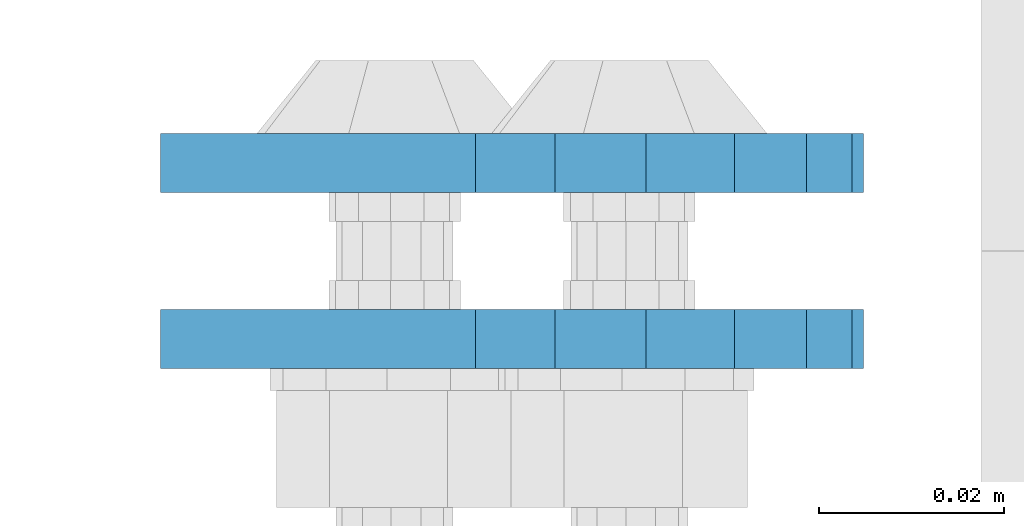
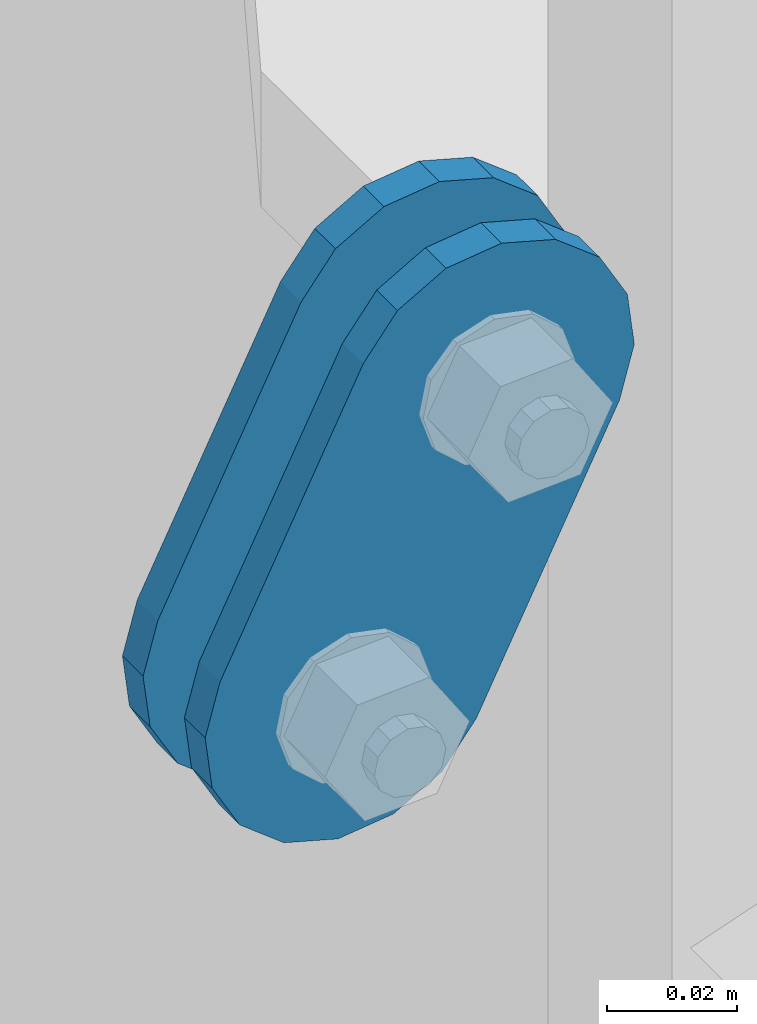
# One storey, part 1545 of 1876: 2 plates, 2 elements without a shape of their own.
"""IFC2X3 building model written with IfcOpenShell, lengths in millimetres."""

import ifcopenshell
import ifcopenshell.guid

model = None  # the IFC model being written
_history = None  # IfcOwnerHistory: only IFC2X3 demands one
_inside = {}  # id of a spatial element -> (the spatial element, [elements in it])
_under = {}  # id of a project, library or spatial element -> (it, [spatial elements below it])
_declared = {}  # id of a project -> (the project, [libraries it declares])
_typed = {}  # id of a type object -> (the type object, [elements of that type])
_made_of = {}  # id of a material, layer set ... -> (it, [elements and type objects made of it])


def new_model(schema):
    """Start an empty IFC model of exactly this schema.

    Asked for "IFC4X3", IfcOpenShell would pick the latest addendum, in which some entities
    have other attributes; the version numbers below select the first issue.
    IFC2X3 requires an IfcOwnerHistory on every rooted entity: one is made here for all.
    """
    global model, _history
    if schema == "IFC4X3":
        model = ifcopenshell.file(schema_version=(4, 3, 0, 0))
    else:
        model = ifcopenshell.file(schema=schema)
    _inside.clear()
    _under.clear()
    _declared.clear()
    _typed.clear()
    _made_of.clear()
    _history = None
    if model.schema == "IFC2X3":
        org = make("IfcOrganization", Name="unknown")
        user = make(
            "IfcPersonAndOrganization",
            ThePerson=make("IfcPerson", FamilyName="unknown"),
            TheOrganization=org,
        )
        app = make(
            "IfcApplication",
            ApplicationDeveloper=org,
            Version="unknown",
            ApplicationFullName="unknown",
            ApplicationIdentifier="unknown",
        )
        _history = make(
            "IfcOwnerHistory",
            OwningUser=user,
            OwningApplication=app,
            ChangeAction="ADDED",
            CreationDate=0,
        )
    return model


def make(cls, **values):
    """One entity of the class cls with the attributes given. An attribute that is None is left unset."""
    return model.create_entity(
        cls, **{name: value for name, value in values.items() if value is not None}
    )


def rooted(cls, **values):
    """An entity with a GlobalId (a new one), such as an element, a storey or a relation."""
    return make(cls, GlobalId=ifcopenshell.guid.new(), OwnerHistory=_history, **values)


def si_unit(unit_type, name, prefix=None):
    """IfcSIUnit, for example si_unit("LENGTHUNIT", "METRE", prefix="MILLI")."""
    return make("IfcSIUnit", UnitType=unit_type, Prefix=prefix, Name=name)


def assignment(units):
    """IfcUnitAssignment: the units of a project."""
    return None if units is None else make("IfcUnitAssignment", Units=units)


def point(xyz):
    """IfcCartesianPoint."""
    return None if xyz is None else make("IfcCartesianPoint", Coordinates=xyz)


def direction(xyz):
    """IfcDirection."""
    return None if xyz is None else make("IfcDirection", DirectionRatios=xyz)


def frame(location, z_axis=None, x_axis=None):
    """IfcAxis2Placement3D, a coordinate frame: its origin and axes. An axis left out is left unset."""
    return make(
        "IfcAxis2Placement3D",
        Location=point(location),
        Axis=direction(z_axis),
        RefDirection=direction(x_axis),
    )


def origin_with_axes():
    """The frame at (0, 0, 0) with the z axis (0, 0, 1) and the x axis (1, 0, 0) written out."""
    return frame((0.0, 0.0, 0.0), z_axis=(0.0, 0.0, 1.0), x_axis=(1.0, 0.0, 0.0))


def place(relative_to, where):
    """IfcLocalPlacement: puts the frame where relative to a parent placement (None: the world)."""
    return make(
        "IfcLocalPlacement", PlacementRelTo=relative_to, RelativePlacement=where
    )


def context(
    kind, dimensions, precision=None, world=None, true_north=None, identifier=None
):
    """IfcGeometricRepresentationContext, for example the 3D "Model" context."""
    return make(
        "IfcGeometricRepresentationContext",
        ContextIdentifier=identifier,
        ContextType=kind,
        CoordinateSpaceDimension=dimensions,
        Precision=precision,
        WorldCoordinateSystem=world,
        TrueNorth=true_north,
    )


def subcontext(parent, identifier, kind, view, scale=None):
    """IfcGeometricRepresentationSubContext, for example "Body" below "Model"."""
    return make(
        "IfcGeometricRepresentationSubContext",
        ContextIdentifier=identifier,
        ContextType=kind,
        ParentContext=parent,
        TargetScale=scale,
        TargetView=view,
    )


def project(units=None, contexts=None):
    """IfcProject with its units and contexts."""
    return rooted(
        "IfcProject",
        Name="project",
        RepresentationContexts=contexts,
        UnitsInContext=assignment(units),
    )


def spatial(cls, under=None, at=None, **own):
    """A site, building, storey or space (cls), placed at a placement, below another one or the project."""
    s = rooted(cls, ObjectPlacement=at, **own)
    if under is not None:
        _under.setdefault(under.id(), (under, []))[1].append(s)
    return s


def faces_of(points, faces, orient=None, outer=None):
    """IfcFace entities. A face is a list of loops; a loop is a list of indices into points, from 0.

    orient and outer hold one flag for each loop. By default every Orientation is true, the
    first loop of a face is its IfcFaceOuterBound and the others are IfcFaceBound.
    """
    made = []
    for i, loops in enumerate(faces):
        bounds = []
        for j, loop in enumerate(loops):
            is_outer = j == 0 if outer is None else outer[i][j]
            bounds.append(
                make(
                    "IfcFaceOuterBound" if is_outer else "IfcFaceBound",
                    Bound=make("IfcPolyLoop", Polygon=[points[k] for k in loop]),
                    Orientation=True if orient is None else orient[i][j],
                )
            )
        made.append(make("IfcFace", Bounds=bounds))
    return made


def faceted_brep(points, faces, orient=None, outer=None, voids=None):
    """IfcFacetedBrep: a solid bounded by flat faces; with voids (closed shells), ...WithVoids."""
    shared = [point(p) for p in points]
    hull = make("IfcClosedShell", CfsFaces=faces_of(shared, faces, orient, outer))
    if voids is None:
        return make("IfcFacetedBrep", Outer=hull)
    return make(
        "IfcFacetedBrepWithVoids",
        Outer=hull,
        Voids=[
            make(cls, CfsFaces=faces_of(shared, fs, o, b)) for cls, fs, o, b in voids
        ],
    )


def shape(context_of_items, identifier, shape_type, items):
    """IfcShapeRepresentation: the items that make up one representation, for example the "Body"."""
    return make(
        "IfcShapeRepresentation",
        ContextOfItems=context_of_items,
        RepresentationIdentifier=identifier,
        RepresentationType=shape_type,
        Items=items,
    )


def material(Name=None, Category=None):
    """IfcMaterial."""
    return make("IfcMaterial", Name=Name, Category=Category)


def made_of(thing, what):
    """Note that an element or type object is made of a material, layer set ...; save() writes the relation."""
    if what is not None:
        _made_of.setdefault(what.id(), (what, []))[1].append(thing)
    return thing


def type_object(cls, material=None, **own):
    """A type object (cls), such as IfcWallType, which elements share."""
    return made_of(rooted(cls, **own), material)


def element(
    cls,
    number,
    at=None,
    inside=None,
    cuts=None,
    type_object=None,
    material=None,
    context=None,
    identifier="Body",
    shape_type=None,
    held_by="IfcProductDefinitionShape",
    body=None,
    shapes=None,
    **own,
):
    """One element of the class cls, such as IfcWall. Its Tag is "e" and its number.

    at: its placement. inside: the storey or other place that contains it. cuts: it is an
    opening in that element (IfcRelVoidsElement). A single representation is given by context,
    identifier, shape_type and body (its items); several are given by shapes. held_by: the class
    of the entity that holds the representations. save() writes the other relations.
    """
    e = rooted(cls, Tag="e%d" % number, ObjectPlacement=at, **own)
    if body is not None:
        shapes = [shape(context, identifier, shape_type, body)]
    if shapes is not None:
        e.Representation = make(held_by, Representations=shapes)
    if inside is not None:
        _inside.setdefault(inside.id(), (inside, []))[1].append(e)
    if cuts is not None:
        rooted(
            "IfcRelVoidsElement", RelatingBuildingElement=cuts, RelatedOpeningElement=e
        )
    if type_object is not None:
        _typed.setdefault(type_object.id(), (type_object, []))[1].append(e)
    return made_of(e, material)


def aggregate(whole, parts):
    """IfcRelAggregates: a whole, such as a stair, and the parts it consists of."""
    return rooted("IfcRelAggregates", RelatingObject=whole, RelatedObjects=parts)


def save(model, path):
    """Write the relations noted so far, then the file.

    IfcRelAggregates (storeys below a building ...), IfcRelContainedInSpatialStructure (elements
    in a storey), IfcRelDefinesByType, IfcRelAssociatesMaterial and IfcRelDeclares: one each for
    every whole, place, type object, material and project.
    """
    for whole, parts in _under.values():
        aggregate(whole, parts)
    for where, things in _inside.values():
        rooted(
            "IfcRelContainedInSpatialStructure",
            RelatedElements=things,
            RelatingStructure=where,
        )
    for kind, things in _typed.values():
        rooted("IfcRelDefinesByType", RelatedObjects=things, RelatingType=kind)
    for what, things in _made_of.values():
        rooted("IfcRelAssociatesMaterial", RelatedObjects=things, RelatingMaterial=what)
    for by, libraries in _declared.values():
        rooted("IfcRelDeclares", RelatingContext=by, RelatedDefinitions=libraries)
    model.write(path)


model = new_model("IFC2X3")

# Units and contexts
model_context = context("Model", 3, precision=1e-05, world=origin_with_axes())
body_context = subcontext(model_context, "Body", "Model", "MODEL_VIEW")
ifc_project = project(units=[si_unit("LENGTHUNIT", "METRE", prefix="MILLI"), si_unit("AREAUNIT", "SQUARE_METRE"), si_unit("VOLUMEUNIT", "CUBIC_METRE"), si_unit("MASSUNIT", "GRAM", prefix="KILO"), si_unit("TIMEUNIT", "SECOND"), si_unit("PLANEANGLEUNIT", "RADIAN"), si_unit("SOLIDANGLEUNIT", "STERADIAN"), si_unit("THERMODYNAMICTEMPERATUREUNIT", "DEGREE_CELSIUS"), si_unit("LUMINOUSINTENSITYUNIT", "LUMEN")], contexts=[model_context])

# Site, building, storey
site_placement = place(None, origin_with_axes())
site = spatial("IfcSite", under=ifc_project, at=site_placement, CompositionType="ELEMENT")
building_placement = place(site_placement, origin_with_axes())
building = spatial("IfcBuilding", under=site, at=building_placement, Name="Undefined", CompositionType="ELEMENT")
storey_placement = place(building_placement, origin_with_axes())
storey = spatial("IfcBuildingStorey", under=building, at=storey_placement, Name="Undefined", CompositionType="ELEMENT", Elevation=0.0)

# Assembly, plate
assembly_1_placement = place(storey_placement, origin_with_axes())
assembly_1 = element("IfcElementAssembly", 1, at=assembly_1_placement, inside=storey, Name="PLATE", AssemblyPlace="NOTDEFINED", PredefinedType="RIGID_FRAME")
ifc_material = material(Name="STEEL/A36")
plate_type = type_object("IfcPlateType", PredefinedType="NOTDEFINED")
plate_1_placement = place(assembly_1_placement, frame((-354.259224851122, 1514.47500379472, 7895.37767748094), z_axis=(0.894427191199916, 0.0, -0.447213595099958), x_axis=(-0.447213595099961, 6.99999707257306e-09, -0.894427191199915)))
plate_1 = element("IfcPlate", 2, at=plate_1_placement, type_object=plate_type, material=ifc_material, Name="PLATE", context=body_context, shape_type="Brep", body=[
    faceted_brep([(-8.59611645864788e-07, -3.17499999999654, 25.3999987589127), (1.93345873884391, -3.17499999999382, 35.1201580589886), (1.93345873884391, 3.17500000000564, 35.1201580589886), (-8.59611645864788e-07, 3.17500000000382, 25.3999987589132), (7.43948648259902, -3.17499999999109, 43.3605112870105), (7.43948648259902, 3.17500000000928, 43.3605112870105), (15.6798395242777, -3.17499999998654, 48.8665393096448), (15.6798395242777, 3.17500000001382, 48.8665393096448), (25.3999987589095, -3.17499999998199, 50.7999992370592), (25.3999987589095, 3.17500000001837, 50.7999992370592), (82.196130752618, -3.17499999998381, 50.7999992370605), (82.196130752618, 3.17500000001655, 50.7999992370642), (91.9162897887145, -3.17499999997926, 48.8665393918873), (91.9162897887145, 3.1750000000211, 48.8665393918909), (100.156642725027, -3.17499999997472, 43.3605115909359), (100.156642725027, 3.17500000002565, 43.3605115909395), (105.662670525982, -3.17499999997108, 35.1201586546285), (105.662670525986, 3.17500000002929, 35.1201586546358), (107.596130371159, -3.17499999996744, 25.3999996185757), (107.596130371159, 3.17500000003292, 25.3999996185794), (105.662670525981, -3.17499999996471, 15.6798405824902), (105.662670525981, 3.17500000003565, 15.6798405824939), (100.156642725024, -3.17499999996471, 7.43948764618654), (100.156642725025, 3.17500000003565, 7.43948764619017), (91.9162897887127, -3.17499999996562, 1.93345984522784), (91.9162897887127, 3.17500000003474, 1.93345984523148), (82.196130752618, -3.17499999996835, 4.54747350886464e-11), (82.196130752618, 3.1750000000311, 4.91127138957381e-11), (25.399998758905, -3.17499999999018, -8.64019966684282e-12), (25.399998758905, 3.17500000001019, -8.64019966684282e-12), (15.679839921364, -3.17499999999382, 1.9334597629304), (15.679839921364, 3.17500000000655, 1.9334597629304), (7.43948709043525, -3.17499999999654, 7.43948734220839), (7.43948709043525, 3.17500000000382, 7.43948734220885), (1.93345923228208, -3.17499999999654, 15.6798399868012), (1.93345923228208, 3.17500000000291, 15.6798399868012)], [[[0, 1, 2, 3]], [[1, 4, 5, 2]], [[4, 6, 7, 5]], [[6, 8, 9, 7]], [[8, 10, 11, 9]], [[10, 12, 13, 11]], [[12, 14, 15, 13]], [[14, 16, 17, 15]], [[16, 18, 19, 17]], [[18, 20, 21, 19]], [[20, 22, 23, 21]], [[22, 24, 25, 23]], [[24, 26, 27, 25]], [[26, 28, 29, 27]], [[28, 30, 31, 29]], [[30, 32, 33, 31]], [[32, 34, 35, 33]], [[34, 0, 3, 35]], [[5, 7, 9, 11, 13, 15, 17, 19, 21, 23, 25, 27, 29, 31, 33, 35, 3, 2]], [[34, 32, 30, 28, 26, 24, 22, 20, 18, 16, 14, 12, 10, 8, 6, 4, 1, 0]]]),
])
aggregate(assembly_1, [plate_1])

assembly_2_placement = place(storey_placement, origin_with_axes())
assembly_2 = element("IfcElementAssembly", 3, at=assembly_2_placement, inside=storey, Name="PLATE", AssemblyPlace="NOTDEFINED", PredefinedType="RIGID_FRAME")
plate_2_placement = place(assembly_2_placement, frame((-354.259224851122, 1533.5362000994, 7895.37767748094), z_axis=(0.894427191199916, 0.0, -0.447213595099958), x_axis=(-0.447213595099961, 6.99999707257306e-09, -0.894427191199915)))
plate_2 = element("IfcPlate", 4, at=plate_2_placement, type_object=plate_type, material=ifc_material, Name="PLATE", context=body_context, shape_type="Brep", body=[
    faceted_brep([(-8.59611645864788e-07, -3.17499999999654, 25.3999987589127), (1.93345873884391, -3.17499999999382, 35.1201580589886), (1.93345873884391, 3.17500000000564, 35.1201580589886), (-8.59611645864788e-07, 3.17500000000382, 25.3999987589132), (7.43948648259902, -3.17499999999109, 43.3605112870105), (7.43948648259902, 3.17500000000928, 43.3605112870105), (15.6798395242777, -3.17499999998654, 48.8665393096448), (15.6798395242777, 3.17500000001382, 48.8665393096448), (25.3999987589095, -3.17499999998199, 50.7999992370592), (25.3999987589095, 3.17500000001837, 50.7999992370592), (82.196130752618, -3.17499999998381, 50.7999992370605), (82.196130752618, 3.17500000001655, 50.7999992370642), (91.9162897887145, -3.17499999997926, 48.8665393918873), (91.9162897887145, 3.1750000000211, 48.8665393918909), (100.156642725027, -3.17499999997472, 43.3605115909359), (100.156642725027, 3.17500000002565, 43.3605115909395), (105.662670525982, -3.17499999997108, 35.1201586546285), (105.662670525986, 3.17500000002929, 35.1201586546358), (107.596130371159, -3.17499999996744, 25.3999996185757), (107.596130371159, 3.17500000003292, 25.3999996185794), (105.662670525981, -3.17499999996471, 15.6798405824902), (105.662670525981, 3.17500000003565, 15.6798405824939), (100.156642725024, -3.17499999996471, 7.43948764618654), (100.156642725025, 3.17500000003565, 7.43948764619017), (91.9162897887127, -3.17499999996562, 1.93345984522784), (91.9162897887127, 3.17500000003474, 1.93345984523148), (82.196130752618, -3.17499999996835, 4.54747350886464e-11), (82.196130752618, 3.1750000000311, 4.91127138957381e-11), (25.399998758905, -3.17499999999018, -8.64019966684282e-12), (25.399998758905, 3.17500000001019, -8.64019966684282e-12), (15.679839921364, -3.17499999999382, 1.9334597629304), (15.679839921364, 3.17500000000655, 1.9334597629304), (7.43948709043525, -3.17499999999654, 7.43948734220839), (7.43948709043525, 3.17500000000382, 7.43948734220885), (1.93345923228208, -3.17499999999654, 15.6798399868012), (1.93345923228208, 3.17500000000291, 15.6798399868012)], [[[0, 1, 2, 3]], [[1, 4, 5, 2]], [[4, 6, 7, 5]], [[6, 8, 9, 7]], [[8, 10, 11, 9]], [[10, 12, 13, 11]], [[12, 14, 15, 13]], [[14, 16, 17, 15]], [[16, 18, 19, 17]], [[18, 20, 21, 19]], [[20, 22, 23, 21]], [[22, 24, 25, 23]], [[24, 26, 27, 25]], [[26, 28, 29, 27]], [[28, 30, 31, 29]], [[30, 32, 33, 31]], [[32, 34, 35, 33]], [[34, 0, 3, 35]], [[5, 7, 9, 11, 13, 15, 17, 19, 21, 23, 25, 27, 29, 31, 33, 35, 3, 2]], [[34, 32, 30, 28, 26, 24, 22, 20, 18, 16, 14, 12, 10, 8, 6, 4, 1, 0]]]),
])
aggregate(assembly_2, [plate_2])

save(model, "model.ifc")
